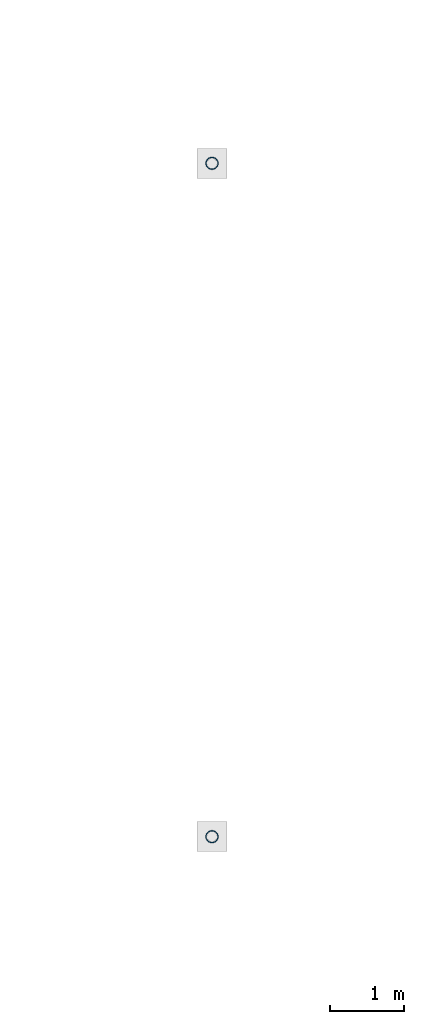
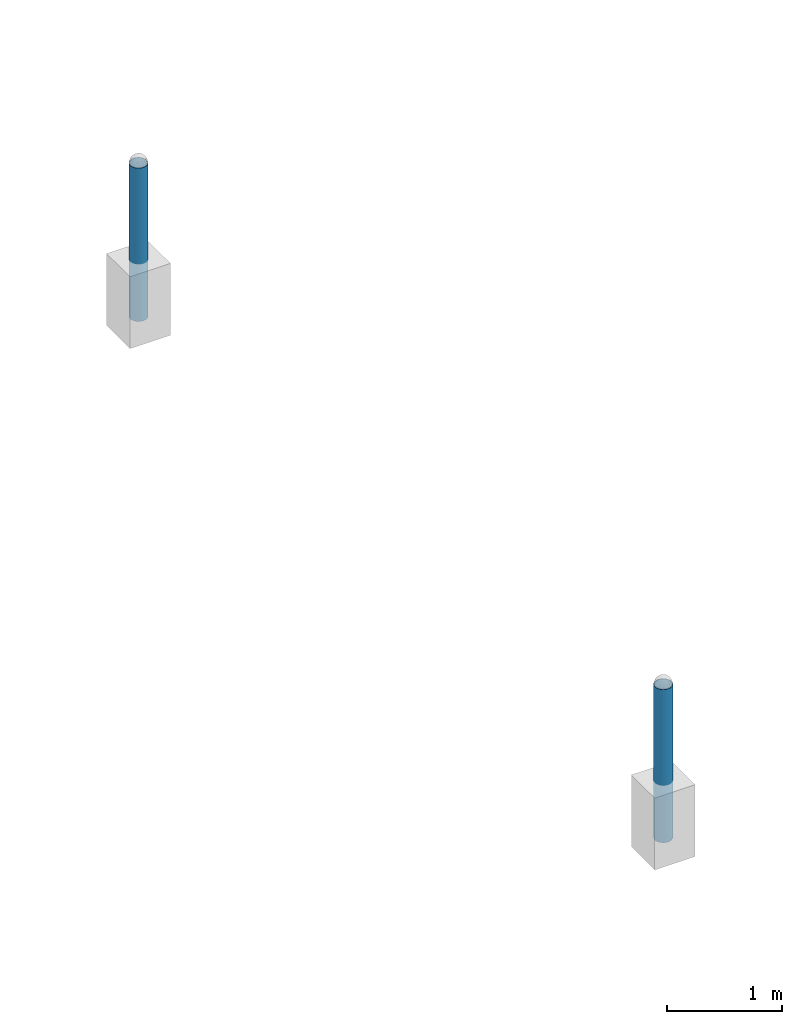
# One storey, part 1352 of 3843: 2 columns, 2 elements without a shape of their own.
"""IFC2X3 building model written with IfcOpenShell, lengths in millimetres."""

from ifc_helpers import new_model, si_unit, frame, origin_with_axes, place, context, subcontext, project, spatial, faceted_brep, material, type_object, element, aggregate, save


model = new_model("IFC2X3")

# Units and contexts
model_context = context("Model", 3, precision=1e-05, world=origin_with_axes())
body_context = subcontext(model_context, "Body", "Model", "MODEL_VIEW")
ifc_project = project(units=[si_unit("LENGTHUNIT", "METRE", prefix="MILLI"), si_unit("AREAUNIT", "SQUARE_METRE"), si_unit("VOLUMEUNIT", "CUBIC_METRE"), si_unit("MASSUNIT", "GRAM", prefix="KILO"), si_unit("TIMEUNIT", "SECOND"), si_unit("PLANEANGLEUNIT", "RADIAN"), si_unit("SOLIDANGLEUNIT", "STERADIAN"), si_unit("THERMODYNAMICTEMPERATUREUNIT", "DEGREE_CELSIUS"), si_unit("LUMINOUSINTENSITYUNIT", "LUMEN")], contexts=[model_context])

# Site, building, storey
site_placement = place(None, origin_with_axes())
site = spatial("IfcSite", under=ifc_project, at=site_placement, CompositionType="ELEMENT")
building_placement = place(site_placement, origin_with_axes())
building = spatial("IfcBuilding", under=site, at=building_placement, Name="Undefined", CompositionType="ELEMENT")
storey_placement = place(building_placement, origin_with_axes())
storey = spatial("IfcBuildingStorey", under=building, at=storey_placement, Name="Undefined", CompositionType="ELEMENT", Elevation=0.0)

# Assembly, column
assembly_1_placement = place(storey_placement, origin_with_axes())
assembly_1 = element("IfcElementAssembly", 1, at=assembly_1_placement, inside=storey, Name="PIPE_BOLLARD", AssemblyPlace="NOTDEFINED", PredefinedType="RIGID_FRAME")
ifc_material = material()
column_type = type_object("IfcColumnType", Name="PIPE6SCH40", PredefinedType="NOTDEFINED")
column_1_placement = place(assembly_1_placement, frame((15156.5818631947, 73392.460174799, 29870.4), z_axis=(-1.0, 0.0, 0.0), x_axis=(0.0, 0.0, 1.0)))
column_1 = element("IfcColumn", 2, at=column_1_placement, type_object=column_type, material=ifc_material, Name="PIPE_BOLLARD", ObjectType="PIPE6SCH40", context=body_context, shape_type="Brep", body=[
    faceted_brep([(0.0, -77.0890000000072, 0.0), (0.0, -74.4622560228017, 19.9521013679077), (1625.6, -74.4622560228017, 19.9521013679077), (1625.6, -77.0890000000072, 0.0), (0.0, -66.7610323523404, 38.5445), (1625.6, -66.7610323523404, 38.5445), (0.0, -54.5101546548831, 54.5101546548904), (1625.6, -54.5101546548831, 54.5101546548904), (0.0, -38.5445000000036, 66.7610323523386), (1625.6, -38.5445000000036, 66.7610323523386), (0.0, -19.9521013679041, 74.4622560227981), (1625.6, -19.9521013679041, 74.4622560227981), (0.0, 0.0, 77.0889999999999), (1625.6, 0.0, 77.0889999999999), (0.0, 19.9521013679041, 74.4622560227981), (1625.6, 19.9521013679041, 74.4622560227981), (0.0, 38.5445000000036, 66.7610323523386), (1625.6, 38.5445000000036, 66.7610323523386), (0.0, 54.5101546548831, 54.5101546548904), (1625.6, 54.5101546548831, 54.5101546548904), (0.0, 66.7610323523404, 38.5445), (1625.6, 66.7610323523404, 38.5445), (0.0, 74.4622560228017, 19.9521013679077), (1625.6, 74.4622560228017, 19.9521013679077), (0.0, 77.0890000000072, 0.0), (1625.6, 77.0890000000072, 0.0), (0.0, 74.4622560228017, -19.9521013679077), (1625.6, 74.4622560228017, -19.9521013679077), (0.0, 66.7610323523404, -38.5445), (1625.6, 66.7610323523404, -38.5445), (0.0, 54.5101546548831, -54.5101546548904), (1625.6, 54.5101546548831, -54.5101546548904), (0.0, 38.5445000000036, -66.7610323523386), (1625.6, 38.5445000000036, -66.7610323523386), (0.0, 19.9521013679041, -74.4622560227981), (1625.6, 19.9521013679041, -74.4622560227981), (0.0, 0.0, -77.0889999999999), (1625.6, 0.0, -77.0889999999999), (0.0, -19.9521013679041, -74.4622560227981), (1625.6, -19.9521013679041, -74.4622560227981), (0.0, -38.5445000000036, -66.7610323523386), (1625.6, -38.5445000000036, -66.7610323523386), (0.0, -54.5101546548831, -54.5101546548904), (1625.6, -54.5101546548831, -54.5101546548904), (0.0, -66.7610323523404, -38.5445), (1625.6, -66.7610323523404, -38.5445), (0.0, -74.4622560228017, -19.9521013679077), (1625.6, -74.4622560228017, -19.9521013679077), (0.0, -84.2010000000009, 0.0), (0.0, -81.3319204993604, -21.7928224166772), (1625.6, -81.3319204993604, -21.7928224166772), (1625.6, -84.2010000000009, 0.0), (0.0, -72.9202050240565, -42.1005000000005), (1625.6, -72.9202050240565, -42.1005000000005), (0.0, -59.5390980826924, -59.5390980826887), (1625.6, -59.5390980826924, -59.5390980826887), (0.0, -42.1005000000005, -72.9202050240528), (1625.6, -42.1005000000005, -72.9202050240528), (0.0, -21.7928224166826, -81.3319204993659), (1625.6, -21.7928224166826, -81.3319204993659), (0.0, 0.0, -84.2009999999991), (1625.6, 0.0, -84.2009999999991), (0.0, 21.7928224166826, -81.3319204993659), (1625.6, 21.7928224166826, -81.3319204993659), (0.0, 42.1005000000005, -72.9202050240528), (1625.6, 42.1005000000005, -72.9202050240528), (0.0, 59.5390980826924, -59.5390980826887), (1625.6, 59.5390980826924, -59.5390980826887), (0.0, 72.9202050240565, -42.1005000000005), (1625.6, 72.9202050240565, -42.1005000000005), (0.0, 81.3319204993604, -21.7928224166772), (1625.6, 81.3319204993604, -21.7928224166772), (0.0, 84.2010000000009, 0.0), (1625.6, 84.2010000000009, 0.0), (0.0, 81.3319204993604, 21.7928224166772), (1625.6, 81.3319204993604, 21.7928224166772), (0.0, 72.9202050240565, 42.1005000000005), (1625.6, 72.9202050240565, 42.1005000000005), (0.0, 59.5390980826924, 59.5390980826887), (1625.6, 59.5390980826924, 59.5390980826887), (0.0, 42.1005000000005, 72.9202050240528), (1625.6, 42.1005000000005, 72.9202050240528), (0.0, 21.7928224166826, 81.3319204993659), (1625.6, 21.7928224166826, 81.3319204993659), (0.0, 0.0, 84.2009999999991), (1625.6, 0.0, 84.2009999999991), (0.0, -21.7928224166826, 81.3319204993659), (1625.6, -21.7928224166826, 81.3319204993659), (0.0, -42.1005000000005, 72.9202050240528), (1625.6, -42.1005000000005, 72.9202050240528), (0.0, -59.5390980826924, 59.5390980826887), (1625.6, -59.5390980826924, 59.5390980826887), (0.0, -72.9202050240565, 42.1005000000005), (1625.6, -72.9202050240565, 42.1005000000005), (0.0, -81.3319204993604, 21.7928224166772), (1625.6, -81.3319204993604, 21.7928224166772)], [[[0, 1, 2, 3]], [[1, 4, 5, 2]], [[4, 6, 7, 5]], [[6, 8, 9, 7]], [[8, 10, 11, 9]], [[10, 12, 13, 11]], [[12, 14, 15, 13]], [[14, 16, 17, 15]], [[16, 18, 19, 17]], [[18, 20, 21, 19]], [[20, 22, 23, 21]], [[22, 24, 25, 23]], [[24, 26, 27, 25]], [[26, 28, 29, 27]], [[28, 30, 31, 29]], [[30, 32, 33, 31]], [[32, 34, 35, 33]], [[34, 36, 37, 35]], [[36, 38, 39, 37]], [[38, 40, 41, 39]], [[40, 42, 43, 41]], [[42, 44, 45, 43]], [[44, 46, 47, 45]], [[46, 0, 3, 47]], [[48, 49, 50, 51]], [[49, 52, 53, 50]], [[52, 54, 55, 53]], [[54, 56, 57, 55]], [[56, 58, 59, 57]], [[58, 60, 61, 59]], [[60, 62, 63, 61]], [[62, 64, 65, 63]], [[64, 66, 67, 65]], [[66, 68, 69, 67]], [[68, 70, 71, 69]], [[70, 72, 73, 71]], [[72, 74, 75, 73]], [[74, 76, 77, 75]], [[76, 78, 79, 77]], [[78, 80, 81, 79]], [[80, 82, 83, 81]], [[82, 84, 85, 83]], [[84, 86, 87, 85]], [[86, 88, 89, 87]], [[88, 90, 91, 89]], [[90, 92, 93, 91]], [[92, 94, 95, 93]], [[94, 48, 51, 95]], [[53, 55, 57, 59, 61, 63, 65, 67, 69, 71, 73, 75, 77, 79, 81, 83, 85, 87, 89, 91, 93, 95, 51, 50], [5, 7, 9, 11, 13, 15, 17, 19, 21, 23, 25, 27, 29, 31, 33, 35, 37, 39, 41, 43, 45, 47, 3, 2]], [[94, 92, 90, 88, 86, 84, 82, 80, 78, 76, 74, 72, 70, 68, 66, 64, 62, 60, 58, 56, 54, 52, 49, 48], [46, 44, 42, 40, 38, 36, 34, 32, 30, 28, 26, 24, 22, 20, 18, 16, 14, 12, 10, 8, 6, 4, 1, 0]]]),
])
aggregate(assembly_1, [column_1])

assembly_2_placement = place(storey_placement, origin_with_axes())
assembly_2 = element("IfcElementAssembly", 3, at=assembly_2_placement, inside=storey, Name="PIPE_BOLLARD", AssemblyPlace="NOTDEFINED", PredefinedType="RIGID_FRAME")
column_2_placement = place(assembly_2_placement, frame((15156.5570676625, 64276.8748476505, 29870.4), z_axis=(-1.0, 0.0, 0.0), x_axis=(0.0, 0.0, 1.0)))
column_2 = element("IfcColumn", 4, at=column_2_placement, type_object=column_type, material=ifc_material, Name="PIPE_BOLLARD", ObjectType="PIPE6SCH40", context=body_context, shape_type="Brep", body=[
    faceted_brep([(0.0, -77.0890000000072, 0.0), (0.0, -74.4622560228017, 19.9521013679077), (1625.6, -74.4622560228017, 19.9521013679077), (1625.6, -77.0890000000072, 0.0), (0.0, -66.7610323523404, 38.5445), (1625.6, -66.7610323523404, 38.5445), (0.0, -54.5101546548831, 54.5101546548904), (1625.6, -54.5101546548831, 54.5101546548904), (0.0, -38.5445000000036, 66.7610323523386), (1625.6, -38.5445000000036, 66.7610323523386), (0.0, -19.9521013679041, 74.4622560227981), (1625.6, -19.9521013679041, 74.4622560227981), (0.0, 0.0, 77.0889999999999), (1625.6, 0.0, 77.0889999999999), (0.0, 19.9521013679041, 74.4622560227981), (1625.6, 19.9521013679041, 74.4622560227981), (0.0, 38.5445000000036, 66.7610323523386), (1625.6, 38.5445000000036, 66.7610323523386), (0.0, 54.5101546548831, 54.5101546548904), (1625.6, 54.5101546548831, 54.5101546548904), (0.0, 66.7610323523404, 38.5445), (1625.6, 66.7610323523404, 38.5445), (0.0, 74.4622560228017, 19.9521013679077), (1625.6, 74.4622560228017, 19.9521013679077), (0.0, 77.0890000000072, 0.0), (1625.6, 77.0890000000072, 0.0), (0.0, 74.4622560228017, -19.9521013679077), (1625.6, 74.4622560228017, -19.9521013679077), (0.0, 66.7610323523404, -38.5445), (1625.6, 66.7610323523404, -38.5445), (0.0, 54.5101546548831, -54.5101546548904), (1625.6, 54.5101546548831, -54.5101546548904), (0.0, 38.5445000000036, -66.7610323523386), (1625.6, 38.5445000000036, -66.7610323523386), (0.0, 19.9521013679041, -74.4622560227981), (1625.6, 19.9521013679041, -74.4622560227981), (0.0, 0.0, -77.0889999999999), (1625.6, 0.0, -77.0889999999999), (0.0, -19.9521013679041, -74.4622560227981), (1625.6, -19.9521013679041, -74.4622560227981), (0.0, -38.5445000000036, -66.7610323523386), (1625.6, -38.5445000000036, -66.7610323523386), (0.0, -54.5101546548831, -54.5101546548904), (1625.6, -54.5101546548831, -54.5101546548904), (0.0, -66.7610323523404, -38.5445), (1625.6, -66.7610323523404, -38.5445), (0.0, -74.4622560228017, -19.9521013679077), (1625.6, -74.4622560228017, -19.9521013679077), (0.0, -84.2010000000009, 0.0), (0.0, -81.3319204993604, -21.7928224166772), (1625.6, -81.3319204993604, -21.7928224166772), (1625.6, -84.2010000000009, 0.0), (0.0, -72.9202050240565, -42.1005000000005), (1625.6, -72.9202050240565, -42.1005000000005), (0.0, -59.5390980826924, -59.5390980826887), (1625.6, -59.5390980826924, -59.5390980826887), (0.0, -42.1005000000005, -72.9202050240528), (1625.6, -42.1005000000005, -72.9202050240528), (0.0, -21.7928224166826, -81.3319204993659), (1625.6, -21.7928224166826, -81.3319204993659), (0.0, 0.0, -84.2009999999991), (1625.6, 0.0, -84.2009999999991), (0.0, 21.7928224166826, -81.3319204993659), (1625.6, 21.7928224166826, -81.3319204993659), (0.0, 42.1005000000005, -72.9202050240528), (1625.6, 42.1005000000005, -72.9202050240528), (0.0, 59.5390980826924, -59.5390980826887), (1625.6, 59.5390980826924, -59.5390980826887), (0.0, 72.9202050240565, -42.1005000000005), (1625.6, 72.9202050240565, -42.1005000000005), (0.0, 81.3319204993604, -21.7928224166772), (1625.6, 81.3319204993604, -21.7928224166772), (0.0, 84.2010000000009, 0.0), (1625.6, 84.2010000000009, 0.0), (0.0, 81.3319204993604, 21.7928224166772), (1625.6, 81.3319204993604, 21.7928224166772), (0.0, 72.9202050240565, 42.1005000000005), (1625.6, 72.9202050240565, 42.1005000000005), (0.0, 59.5390980826924, 59.5390980826887), (1625.6, 59.5390980826924, 59.5390980826887), (0.0, 42.1005000000005, 72.9202050240528), (1625.6, 42.1005000000005, 72.9202050240528), (0.0, 21.7928224166826, 81.3319204993659), (1625.6, 21.7928224166826, 81.3319204993659), (0.0, 0.0, 84.2009999999991), (1625.6, 0.0, 84.2009999999991), (0.0, -21.7928224166826, 81.3319204993659), (1625.6, -21.7928224166826, 81.3319204993659), (0.0, -42.1005000000005, 72.9202050240528), (1625.6, -42.1005000000005, 72.9202050240528), (0.0, -59.5390980826924, 59.5390980826887), (1625.6, -59.5390980826924, 59.5390980826887), (0.0, -72.9202050240565, 42.1005000000005), (1625.6, -72.9202050240565, 42.1005000000005), (0.0, -81.3319204993604, 21.7928224166772), (1625.6, -81.3319204993604, 21.7928224166772)], [[[0, 1, 2, 3]], [[1, 4, 5, 2]], [[4, 6, 7, 5]], [[6, 8, 9, 7]], [[8, 10, 11, 9]], [[10, 12, 13, 11]], [[12, 14, 15, 13]], [[14, 16, 17, 15]], [[16, 18, 19, 17]], [[18, 20, 21, 19]], [[20, 22, 23, 21]], [[22, 24, 25, 23]], [[24, 26, 27, 25]], [[26, 28, 29, 27]], [[28, 30, 31, 29]], [[30, 32, 33, 31]], [[32, 34, 35, 33]], [[34, 36, 37, 35]], [[36, 38, 39, 37]], [[38, 40, 41, 39]], [[40, 42, 43, 41]], [[42, 44, 45, 43]], [[44, 46, 47, 45]], [[46, 0, 3, 47]], [[48, 49, 50, 51]], [[49, 52, 53, 50]], [[52, 54, 55, 53]], [[54, 56, 57, 55]], [[56, 58, 59, 57]], [[58, 60, 61, 59]], [[60, 62, 63, 61]], [[62, 64, 65, 63]], [[64, 66, 67, 65]], [[66, 68, 69, 67]], [[68, 70, 71, 69]], [[70, 72, 73, 71]], [[72, 74, 75, 73]], [[74, 76, 77, 75]], [[76, 78, 79, 77]], [[78, 80, 81, 79]], [[80, 82, 83, 81]], [[82, 84, 85, 83]], [[84, 86, 87, 85]], [[86, 88, 89, 87]], [[88, 90, 91, 89]], [[90, 92, 93, 91]], [[92, 94, 95, 93]], [[94, 48, 51, 95]], [[53, 55, 57, 59, 61, 63, 65, 67, 69, 71, 73, 75, 77, 79, 81, 83, 85, 87, 89, 91, 93, 95, 51, 50], [5, 7, 9, 11, 13, 15, 17, 19, 21, 23, 25, 27, 29, 31, 33, 35, 37, 39, 41, 43, 45, 47, 3, 2]], [[94, 92, 90, 88, 86, 84, 82, 80, 78, 76, 74, 72, 70, 68, 66, 64, 62, 60, 58, 56, 54, 52, 49, 48], [46, 44, 42, 40, 38, 36, 34, 32, 30, 28, 26, 24, 22, 20, 18, 16, 14, 12, 10, 8, 6, 4, 1, 0]]]),
])
aggregate(assembly_2, [column_2])

save(model, "model.ifc")
